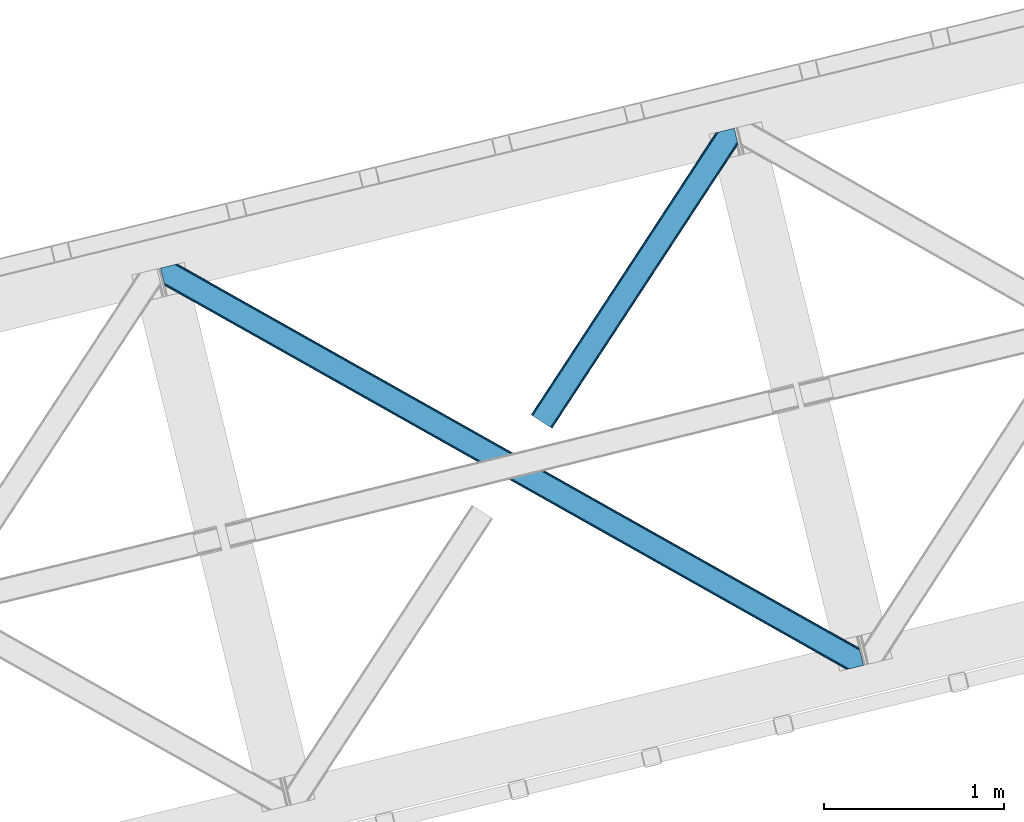
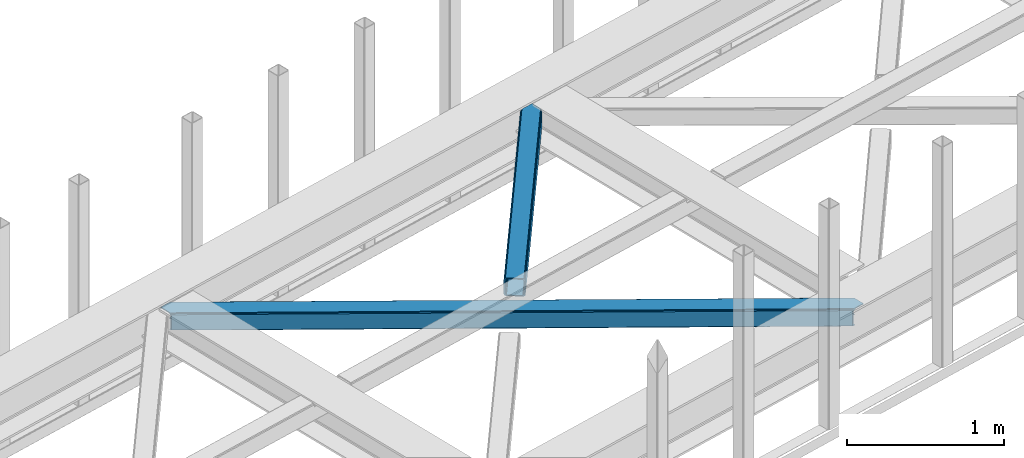
# One storey, part 35 of 67: 2 members.
"""IFC4 building model written with IfcOpenShell, lengths in millimetres."""

from ifc_helpers import new_model, entity, si_unit, converted_unit, derived_unit, direction, frame, origin, place, context, subcontext, project, spatial, triangles, type_object, element, save


model = new_model("IFC4")

# Units and contexts
model_context = context("Model", 3, precision=0.01, world=origin(), true_north=direction((6.12303176911189e-17, 1.0)))
plan_context = context("Plan", 3, precision=0.01, world=origin(), true_north=direction((6.12303176911189e-17, 1.0)))
body_context = subcontext(model_context, "Body", "Model", "MODEL_VIEW")
ifc_project = project(units=[si_unit("LENGTHUNIT", "METRE", prefix="MILLI"), si_unit("AREAUNIT", "SQUARE_METRE"), si_unit("VOLUMEUNIT", "CUBIC_METRE"), converted_unit("PLANEANGLEUNIT", "DEGREE", entity("IfcRatioMeasure", 0.0174532925199433), si_unit("PLANEANGLEUNIT", "RADIAN"), dimensions=[0, 0, 0, 0, 0, 0, 0]), si_unit("MASSUNIT", "GRAM", prefix="KILO"), derived_unit("MASSDENSITYUNIT", [(si_unit("MASSUNIT", "GRAM", prefix="KILO"), 1), (si_unit("LENGTHUNIT", "METRE"), -3)]), derived_unit("MOMENTOFINERTIAUNIT", [(si_unit("LENGTHUNIT", "METRE"), 4)]), si_unit("TIMEUNIT", "SECOND"), si_unit("FREQUENCYUNIT", "HERTZ"), si_unit("THERMODYNAMICTEMPERATUREUNIT", "DEGREE_CELSIUS"), derived_unit("THERMALTRANSMITTANCEUNIT", [(si_unit("MASSUNIT", "GRAM", prefix="KILO"), 1), (si_unit("THERMODYNAMICTEMPERATUREUNIT", "KELVIN"), -1), (si_unit("TIMEUNIT", "SECOND"), -3)]), derived_unit("VOLUMETRICFLOWRATEUNIT", [(si_unit("LENGTHUNIT", "METRE"), 3), (si_unit("TIMEUNIT", "SECOND"), -1)]), derived_unit("MASSFLOWRATEUNIT", [(si_unit("MASSUNIT", "GRAM", prefix="KILO"), 1), (si_unit("TIMEUNIT", "SECOND"), -1)]), derived_unit("ROTATIONALFREQUENCYUNIT", [(si_unit("TIMEUNIT", "SECOND"), -1)]), si_unit("ELECTRICCURRENTUNIT", "AMPERE"), si_unit("ELECTRICVOLTAGEUNIT", "VOLT"), si_unit("POWERUNIT", "WATT"), si_unit("FORCEUNIT", "NEWTON", prefix="KILO"), si_unit("ILLUMINANCEUNIT", "LUX"), si_unit("LUMINOUSFLUXUNIT", "LUMEN"), si_unit("LUMINOUSINTENSITYUNIT", "CANDELA"), derived_unit("USERDEFINED", [(si_unit("MASSUNIT", "GRAM", prefix="KILO"), -1), (si_unit("LENGTHUNIT", "METRE"), -2), (si_unit("TIMEUNIT", "SECOND"), 3), (si_unit("LUMINOUSFLUXUNIT", "LUMEN"), 1)]), derived_unit("LINEARVELOCITYUNIT", [(si_unit("LENGTHUNIT", "METRE"), 1), (si_unit("TIMEUNIT", "SECOND"), -1)]), si_unit("PRESSUREUNIT", "PASCAL"), derived_unit("USERDEFINED", [(si_unit("LENGTHUNIT", "METRE"), -2), (si_unit("MASSUNIT", "GRAM", prefix="KILO"), 1), (si_unit("TIMEUNIT", "SECOND"), -2)]), derived_unit("LINEARFORCEUNIT", [(si_unit("MASSUNIT", "GRAM", prefix="KILO"), 1), (si_unit("LENGTHUNIT", "METRE"), 1), (si_unit("TIMEUNIT", "SECOND"), -2), (si_unit("LENGTHUNIT", "METRE"), -1)]), derived_unit("PLANARFORCEUNIT", [(si_unit("MASSUNIT", "GRAM", prefix="KILO"), 1), (si_unit("LENGTHUNIT", "METRE"), 1), (si_unit("TIMEUNIT", "SECOND"), -2), (si_unit("LENGTHUNIT", "METRE"), -2)])], contexts=[model_context, plan_context])

# Site, building, storey
site_placement = place(None, origin())
site = spatial("IfcSite", under=ifc_project, at=site_placement, CompositionType="ELEMENT")
building_placement = place(site_placement, origin())
building = spatial("IfcBuilding", under=site, at=building_placement, CompositionType="ELEMENT")
storey_placement = place(building_placement, frame((0.0, 0.0, 19800.0)))
storey = spatial("IfcBuildingStorey", under=building, at=storey_placement, CompositionType="ELEMENT", Elevation=19800.0)

# Members
member_type_1 = type_object("IfcMemberType", PredefinedType="BRACE")
member_1_placement = place(storey_placement, frame((-36508.3901733398, 9647.04894561768, 3823.99987792968)))
element("IfcMember", 1, at=member_1_placement, inside=storey, type_object=member_type_1, ObjectType="Steel Horizontal Brace", PredefinedType="BRACE", context=body_context, shape_type="Tessellation", body=[
    triangles([(3809.34190063476, 0.0, 122.499499511719), (3811.23480834961, 0.461599731444949, 129.196765136719), (23.4590332031221, 2133.54825897217, 129.196765136719), (23.8915649414048, 2131.77511138916, 122.499499511719), (3816.62982788086, 1.77663574218786, 134.87548828125), (22.2288757324204, 2138.59446258545, 134.87548828125), (3824.70607910156, 3.74570159912037, 138.668280029298), (20.3871276855498, 2146.14632720947, 138.668280029298), (3834.23107910156, 6.06765289306531, 140.00075683594), (18.2151672363252, 2155.05508575439, 140.00075683594), (1916.9806640625, 1065.68088226318, 17.5012573242202), (2556.11839599609, 705.752851867675, 17.5012573242202), (3195.25147705078, 345.823658752441, 17.5012573242202), (3809.34190063476, 0.0, 17.5012573242202), (1277.84758300781, 1425.61007537842, 17.5012573242202), (638.712176513669, 1785.53926849365, 17.5012573242202), (23.8915649414048, 2131.77511138916, 17.5012573242202), (3885.46283569336, 97.7219421386708, 140.00075683594), (3903.67800292969, 22.9956893920898, 140.00075683594), (69.4469238281235, 2246.70995635986, 140.00075683594), (0.0, 2229.78191986084, 140.00075683594), (3883.29087524414, 106.63011932373, 138.668280029298), (78.971923828125, 2249.03190765381, 138.668280029298), (3881.44912719727, 114.183146667479, 134.87548828125), (87.0458496093779, 2251.00039215088, 134.87548828125), (3880.21896972656, 119.229350280761, 129.196765136719), (92.4408691406279, 2252.31542816162, 129.196765136719), (3879.78643798828, 121.001335144043, 122.499499511719), (94.3384277343721, 2252.77702789307, 122.499499511719), (3265.41928710938, 466.982542419433, 17.5012573242202), (3879.78643798828, 121.001335144043, 17.5012573242202), (2626.2955078125, 826.904759216308, 17.5012573242202), (1987.16940307617, 1186.82813873291, 17.5012573242202), (708.921844482422, 1906.67257232666, 17.5012573242202), (94.3384277343721, 2252.77702789307, 17.5012573242202), (1348.0456237793, 1546.75035552978, 17.5012573242202), (82.4856628417983, 2249.88766937256, 122.197192382813), (69.0143920898408, 2246.60531158447, 131.668707275392), (59.4893920898467, 2244.28336029053, 133.001184082033), (0.0, 2229.78191986084, 133.001184082033), (77.0906433105483, 2248.57263336182, 127.873590087893), (84.3808959960952, 2250.35043182373, 24.5008300781265), (77.0906433105483, 2248.57263336182, 12.1248413085959), (91.582781982419, 2252.10613861084, 9.49942016601563), (82.4856628417983, 2249.88766937256, 17.8035644531265), (84.3808959960952, 2250.35043182373, 115.499926757813), (72.3118652343765, 2247.40875091553, 9.49942016601563), (92.0548461914077, 2252.22124786377, 10.8691040039084), (1983.49055786133, 1180.86803741455, 24.5008300781265), (3882.05839233398, 111.689112854003, 115.499926757813), (2626.78850097656, 818.593638610839, 24.5008300781265), (3270.08876953125, 456.319239807128, 24.5008300781265), (3882.05839233398, 111.689112854003, 24.5008300781265), (1340.19028930664, 1543.14127349854, 24.5008300781265), (696.892346191409, 1905.41567230225, 24.5008300781265), (3882.48859863281, 109.917127990722, 122.197192382813), (3883.71875610352, 104.870924377441, 127.873590087893), (3885.56050415039, 97.318478393554, 131.668707275392), (3887.73246459961, 88.4097198486324, 133.001184082033), (3883.71875610352, 104.870924377441, 12.1248413085959), (3885.41865234375, 97.9004196166989, 8.52041015625218), (3880.59104003906, 117.702699279786, 8.52041015625218), (3903.67800292969, 22.9956893920898, 133.001184082033), (3882.48859863281, 109.917127990722, 17.8035644531265), (3880.37477416992, 118.591017150879, 10.9365417480476), (3844.18628540039, 8.49366760253906, 133.001184082033), (15.945538330081, 2164.36730804443, 133.001184082033), (3834.66128540039, 6.17229766845594, 131.668707275392), (18.1174987792983, 2155.45854949951, 131.668707275392), (3826.58735961914, 4.20381317138708, 127.873590087893), (19.959246826169, 2147.90668487549, 127.873590087893), (3821.19001464844, 2.88877716064417, 122.197192382813), (21.1894042968779, 2142.85931854248, 122.197192382813), (3819.29478149414, 2.42659606933557, 115.499926757813), (21.6219360351533, 2141.0873336792, 115.499926757813), (3208.50183105469, 346.395716857909, 24.5008300781265), (3819.29478149414, 2.42659606933557, 24.5008300781265), (2565.16435546875, 708.689881896973, 24.5008300781265), (1921.82920532227, 1070.98520965576, 24.5008300781265), (635.156579589842, 1795.57470245361, 24.5008300781265), (21.6219360351533, 2141.0873336792, 24.5008300781265), (1278.49405517578, 1433.28053741455, 24.5008300781265), (21.1894042968779, 2142.85931854248, 17.8035644531265), (23.263696289061, 2134.3505355835, 9.49942016601563), (19.959246826169, 2147.90668487549, 12.1248413085959), (23.3706665039063, 2133.90986480713, 10.8691040039084), (18.8686157226548, 2152.37617950439, 9.49942016601563), (3826.58735961914, 4.20381317138708, 12.1248413085959), (3812.8672668457, 0.859831237792605, 8.52041015625218), (3821.19001464844, 2.88877716064417, 17.8035644531265), (3834.04039306641, 6.02056274414099, 8.52041015625218), (3811.91848754883, 0.628450012207395, 10.9365417480476), (190.669757080075, 2055.62743377686, 9.49942016601563), (195.064837646481, 2037.60178985596, 9.49942016601563), (196.076403808591, 2037.6692276001, 8.49948120117188), (196.057800292969, 2037.42389373779, 8.8831787109375), (191.292974853517, 2056.67155609131, 8.85294799804615), (195.734564208986, 2037.48202972412, 9.08316650390771), (191.348785400391, 2055.8262588501, 9.20641479492406), (195.385748291017, 2037.54365386963, 9.29943237304906), (191.009271240233, 2055.72626495361, 9.35291748046802), (191.239489746091, 2057.51685333252, 8.49948120117188), (150.921020507813, 2218.69073638916, 9.49942016601563), (155.316101074219, 2200.66509246826, 9.49942016601563), (151.251232910159, 2218.34889678955, 9.25757446289208), (155.811419677731, 2200.23721160889, 9.42500610351635), (151.609350585939, 2217.98496551514, 8.99945068359375), (156.250927734378, 2199.30471038818, 9.11804809570458), (151.96281738281, 2217.619871521, 8.74132690429906), (156.692761230472, 2198.36407012939, 8.80643920898365), (152.295355224611, 2217.27919464111, 8.49948120117188), (157.132269287111, 2197.43156890869, 8.49948120117188), (3713.61751098633, 194.649165344237, 8.52041015625218), (3708.78989868164, 214.452607727051, 8.52041015625218), (3713.26636962891, 194.529405212403, 8.40181274414135), (3708.39922485351, 214.57120513916, 8.37390747070458), (3713.06405639648, 194.459642028809, 8.3320495605476), (3708.00622558594, 214.688639831542, 8.22740478515698), (3707.90623168946, 214.477024841308, 7.87393798828271), (3713.112890625, 193.949208068847, 8.19484863281468), (3707.80623779297, 214.266572570801, 7.52047119140843), (3713.24078979492, 192.705097961425, 7.85765991211156), (3713.36636352539, 191.464476013183, 7.52047119140843), (3264.76583862305, 465.822148132323, 10.8039916992202), (3262.90548706055, 462.516535949706, 5.12526855468968), (3260.11728515625, 457.569163513183, 1.33247680664135), (3708.58293457031, 211.087696838378, 5.59500732422021), (708.268395996092, 1905.51217803955, 10.8039916992202), (706.408044433592, 1902.20772857666, 5.12526855468968), (153.148791503903, 2213.77475738525, 5.12526855468968), (703.622167968751, 1897.26035614014, 1.33247680664135), (154.990539550781, 2206.22289276123, 1.33247680664135), (700.336322021481, 1891.42466583252, 0.0), (157.162499999999, 2197.31413421631, 0.0), (3710.29678344727, 204.050917053222, 1.33247680664135), (3712.46874389648, 195.142158508301, 0.0), (3256.83143920898, 451.734635925293, 0.0), (2625.64205932617, 825.744364929198, 10.8039916992202), (1986.51595458984, 1185.6677444458, 10.8039916992202), (1347.39450073242, 1545.58996124267, 10.8039916992202), (2623.77938232422, 822.438752746582, 5.12526855468968), (1984.65560302734, 1182.36213226318, 5.12526855468968), (1345.53182373047, 1542.28434906006, 5.12526855468968), (2620.99583129883, 817.492543029784, 1.33247680664135), (1981.8697265625, 1177.41475982666, 1.33247680664135), (1342.74594726563, 1537.33813934326, 1.33247680664135), (2617.70765991211, 811.656852722168, 0.0), (1978.58388061523, 1171.58023223877, 0.0), (1339.45777587891, 1531.50244903564, 0.0), (3746.51782836914, 55.4634750366204, 0.0), (3203.83932495117, 361.072727966308, 0.0), (2564.70391845703, 721.000758361815, 0.0), (1925.56851196289, 1080.92995147705, 0.0), (1286.43310546875, 1440.85798187256, 0.0), (647.297698974609, 1800.78717498779, 0.0), (191.209259033203, 2057.6342880249, 0.0), (3195.90492553711, 346.98405303955, 10.8039916992202), (639.365624999999, 1786.69966278076, 10.8039916992202), (641.225976562499, 1790.00527496338, 5.12526855468968), (195.222967529298, 2041.17366485596, 5.12526855468968), (3197.76760253906, 350.290827941893, 5.12526855468968), (3200.55115356445, 355.237037658691, 1.33247680664135), (3748.6874633789, 46.5547164916989, 1.33247680664135), (3752.58024902344, 34.8100845336903, 8.52041015625218), (3750.40363769531, 39.517936706543, 5.59500732422021), (3751.1780090332, 36.3402236938473, 7.52047119140843), (3752.24073486328, 35.1809921264648, 8.278564453125), (644.014178466794, 1794.9526473999, 1.33247680664135), (193.38121948242, 2048.72552947998, 1.33247680664135), (2561.41807250977, 715.166230773926, 1.33247680664135), (1922.28266601563, 1075.09426116943, 1.33247680664135), (1283.14725952149, 1435.02345428467, 1.33247680664135), (2558.63219604492, 710.218858337403, 5.12526855468968), (1919.49678955078, 1070.14805145264, 5.12526855468968), (1280.36370849609, 1430.07724456787, 5.12526855468968), (2556.76951904297, 706.913246154785, 10.8039916992202), (1917.63643798828, 1066.84243927002, 10.8039916992202), (1278.50103149414, 1426.77046966553, 10.8039916992202), (3745.62020874023, 59.1411575317379, 7.52047119140843), (3746.13878173828, 57.3430114746097, 7.90416870117406), (3746.67595825195, 56.436090087891, 8.10880737304615), (3747.30150146484, 55.3762710571282, 8.34832763671875), (3747.75263671875, 54.6129455566406, 8.52041015625218), (3211.01795654297, 350.861723327636, 12.1248413085959), (3217.08967895508, 361.643623352051, 6.99957275390625), (3213.80383300781, 355.80909576416, 8.3320495605476), (3744.24819946289, 64.7751159667969, 6.99957275390625), (643.744427490237, 1810.82377166748, 6.99957275390625), (188.939630126952, 2066.94651031494, 6.99957275390625), (637.672705078126, 1800.04187164307, 12.1248413085959), (640.456256103513, 1804.98808135986, 8.3320495605476), (635.810028076172, 1796.73625946045, 17.8035644531265), (3209.15760498047, 347.556111145019, 17.8035644531265), (2565.82012939453, 709.851438903808, 17.8035644531265), (1922.48265380859, 1072.14560394287, 17.8035644531265), (1279.14517822266, 1434.44093170166, 17.8035644531265), (2567.68048095703, 713.157051086426, 12.1248413085959), (1924.34300537109, 1075.45121612549, 12.1248413085959), (1281.00552978516, 1437.74654388428, 12.1248413085959), (2570.46635742187, 718.103260803222, 8.3320495605476), (1927.13120727539, 1080.39858856201, 8.3320495605476), (1283.79373168945, 1442.69275360107, 8.3320495605476), (2573.75220336914, 723.93895111084, 6.99957275390625), (1930.4147277832, 1086.2331161499, 6.99957275390625), (1287.07957763672, 1448.52844390869, 6.99957275390625), (694.376220703125, 1900.94966583252, 12.1248413085959), (691.58801879883, 1896.002293396, 8.3320495605476), (157.267144775389, 2196.88509063721, 8.41343994140698), (159.43212890625, 2188.00191192627, 6.99957275390625), (3261.50092163086, 441.070170593261, 6.99957275390625), (3264.78676757812, 446.905860900879, 8.3320495605476), (3714.73837280273, 185.831098937988, 6.99957275390625), (3267.57496948242, 451.853233337402, 12.1248413085959), (688.304498291014, 1890.16660308838, 6.99957275390625), (696.236572265625, 1904.25411529541, 17.8035644531265), (3269.43532104492, 455.157682800293, 17.8035644531265), (2621.48882446289, 809.18025970459, 8.3320495605476), (2618.20065307617, 803.344569396972, 6.99957275390625), (1978.1885559082, 1171.45349578857, 8.3320495605476), (1974.90270996094, 1165.61896820068, 6.99957275390625), (1331.60244140625, 1527.89220428467, 6.99957275390625), (1334.89061279297, 1533.72789459228, 8.3320495605476), (2624.27237548828, 814.126469421386, 12.1248413085959), (1980.97443237305, 1176.4008682251, 12.1248413085959), (1337.67416381836, 1538.67526702881, 12.1248413085959), (2626.13737792968, 817.432081604004, 17.8035644531265), (1982.83478393555, 1179.70648040771, 17.8035644531265), (1339.53684082031, 1541.98087921143, 17.8035644531265)], [[1, 2, 3], [3, 4, 1], [2, 5, 6], [6, 3, 2], [5, 7, 8], [8, 6, 5], [7, 9, 10], [10, 8, 7], [11, 1, 4], [1, 12, 13], [11, 12, 1], [13, 14, 1], [15, 4, 16], [4, 15, 11], [17, 16, 4], [9, 18, 10], [9, 19, 18], [20, 10, 18], [21, 10, 20], [18, 22, 23], [23, 20, 18], [22, 24, 25], [25, 23, 22], [24, 26, 27], [27, 25, 24], [26, 28, 29], [29, 27, 26], [30, 28, 31], [28, 30, 32], [28, 33, 29], [33, 28, 32], [34, 35, 29], [36, 29, 33], [29, 36, 34], [37, 29, 27], [38, 23, 20], [21, 39, 20], [39, 21, 40], [39, 38, 20], [41, 23, 38], [41, 37, 25], [25, 23, 41], [27, 25, 37], [42, 35, 29], [43, 44, 45], [37, 46, 29], [43, 47, 44], [42, 45, 35], [46, 42, 29], [48, 35, 45], [45, 44, 48], [49, 50, 46], [50, 51, 52], [49, 51, 50], [52, 53, 50], [54, 46, 55], [46, 54, 49], [42, 55, 46], [50, 56, 46], [37, 46, 56], [56, 57, 37], [41, 37, 57], [57, 58, 41], [38, 41, 58], [58, 59, 38], [39, 38, 59], [57, 24, 22], [60, 61, 62], [24, 57, 56], [58, 57, 22], [58, 18, 59], [19, 59, 18], [59, 19, 63], [58, 22, 18], [31, 28, 53], [62, 64, 60], [64, 31, 53], [65, 64, 62], [65, 31, 64], [28, 50, 53], [56, 26, 24], [28, 26, 56], [50, 28, 56], [59, 66, 67], [66, 59, 63], [67, 39, 59], [40, 39, 67], [66, 68, 67], [69, 67, 68], [68, 70, 69], [71, 69, 70], [70, 72, 71], [73, 71, 72], [72, 74, 73], [75, 73, 74], [76, 74, 77], [74, 76, 78], [74, 79, 75], [79, 74, 78], [80, 81, 75], [82, 75, 79], [75, 82, 80], [83, 84, 85], [81, 4, 17], [17, 86, 83], [86, 84, 83], [83, 81, 17], [75, 4, 81], [73, 71, 6], [3, 73, 6], [3, 4, 73], [75, 73, 4], [71, 8, 6], [69, 8, 71], [87, 85, 84], [69, 67, 10], [69, 10, 8], [67, 21, 10], [67, 40, 21], [72, 1, 2], [68, 7, 9], [19, 66, 9], [66, 19, 63], [66, 68, 9], [70, 7, 68], [70, 72, 5], [5, 7, 70], [2, 5, 72], [77, 14, 1], [88, 89, 90], [72, 74, 1], [88, 91, 89], [77, 90, 14], [74, 77, 1], [92, 14, 90], [90, 89, 92], [93, 94, 84], [84, 87, 93], [95, 96, 97], [96, 98, 99], [99, 98, 100], [101, 100, 94], [94, 93, 101], [100, 101, 99], [99, 97, 96], [97, 102, 95], [103, 104, 44], [47, 44, 104], [105, 106, 104], [107, 108, 106], [109, 110, 108], [111, 112, 110], [110, 109, 111], [108, 107, 109], [106, 105, 107], [104, 103, 105], [62, 61, 113], [113, 114, 62], [115, 116, 114], [117, 118, 116], [116, 115, 117], [119, 118, 120], [121, 119, 122], [122, 123, 121], [120, 122, 119], [117, 120, 118], [114, 113, 115], [124, 30, 31], [125, 124, 118], [118, 119, 125], [119, 121, 125], [124, 65, 114], [114, 116, 124], [116, 118, 124], [65, 62, 114], [126, 125, 127], [48, 128, 103], [128, 129, 130], [130, 111, 128], [128, 109, 107], [109, 128, 111], [128, 105, 103], [105, 128, 107], [128, 48, 35], [35, 34, 128], [103, 44, 48], [129, 131, 132], [132, 130, 129], [131, 133, 134], [134, 132, 131], [135, 136, 137], [137, 126, 135], [127, 135, 126], [121, 127, 125], [31, 65, 124], [30, 124, 138], [138, 32, 30], [32, 138, 33], [139, 33, 138], [33, 139, 36], [140, 36, 139], [36, 140, 34], [128, 34, 140], [124, 125, 138], [141, 138, 125], [138, 141, 142], [142, 139, 138], [139, 142, 143], [143, 140, 139], [140, 143, 129], [129, 128, 140], [125, 126, 144], [144, 141, 125], [141, 144, 145], [145, 142, 141], [142, 145, 146], [146, 143, 142], [143, 146, 129], [131, 129, 146], [126, 137, 144], [147, 144, 137], [144, 147, 145], [148, 145, 147], [145, 148, 146], [149, 146, 148], [146, 149, 131], [133, 131, 149], [136, 150, 151], [137, 151, 147], [151, 137, 136], [148, 152, 153], [152, 147, 151], [148, 147, 152], [133, 149, 154], [153, 149, 148], [149, 153, 154], [155, 133, 154], [156, 133, 155], [134, 133, 156], [157, 92, 14], [158, 16, 17], [159, 96, 95], [158, 86, 94], [94, 159, 158], [94, 98, 159], [86, 84, 94], [95, 160, 159], [161, 162, 163], [92, 157, 164], [157, 161, 165], [165, 166, 157], [167, 164, 157], [157, 166, 167], [164, 89, 92], [163, 165, 161], [150, 163, 162], [162, 151, 150], [155, 168, 169], [169, 156, 155], [168, 159, 160], [160, 169, 168], [17, 86, 158], [14, 13, 157], [151, 162, 152], [170, 152, 162], [152, 170, 153], [171, 153, 170], [153, 171, 172], [172, 154, 153], [154, 172, 168], [168, 155, 154], [162, 161, 170], [173, 170, 161], [170, 173, 174], [174, 171, 170], [171, 174, 175], [175, 172, 171], [172, 175, 168], [159, 168, 175], [161, 157, 176], [176, 173, 161], [173, 176, 174], [177, 174, 176], [174, 177, 175], [178, 175, 177], [175, 178, 159], [158, 159, 178], [157, 13, 12], [12, 176, 157], [176, 12, 11], [11, 177, 176], [177, 11, 15], [15, 178, 177], [178, 15, 16], [16, 158, 178], [166, 179, 180], [166, 180, 181], [167, 181, 182], [167, 182, 183], [91, 89, 183], [164, 183, 89], [184, 183, 182], [88, 91, 183], [183, 184, 88], [185, 180, 179], [182, 185, 186], [182, 181, 185], [180, 185, 181], [179, 187, 185], [188, 189, 102], [93, 85, 190], [93, 87, 85], [102, 190, 191], [190, 102, 97], [97, 99, 190], [80, 192, 81], [83, 81, 192], [192, 190, 83], [85, 83, 190], [102, 191, 188], [182, 186, 184], [90, 88, 184], [184, 193, 90], [77, 90, 193], [193, 76, 77], [76, 193, 78], [194, 78, 193], [78, 194, 79], [195, 79, 194], [79, 195, 82], [196, 82, 195], [82, 196, 80], [192, 80, 196], [193, 184, 197], [197, 194, 193], [194, 197, 195], [198, 195, 197], [195, 198, 199], [199, 196, 195], [196, 199, 190], [190, 192, 196], [184, 186, 197], [200, 197, 186], [197, 200, 201], [201, 198, 197], [198, 201, 202], [202, 199, 198], [199, 202, 191], [191, 190, 199], [186, 185, 203], [203, 200, 186], [200, 203, 201], [204, 201, 203], [201, 204, 202], [205, 202, 204], [202, 205, 191], [188, 191, 205], [206, 106, 108], [108, 207, 206], [108, 110, 207], [110, 208, 207], [104, 206, 43], [43, 47, 104], [207, 208, 209], [210, 123, 122], [122, 211, 210], [122, 117, 211], [210, 212, 123], [213, 211, 117], [61, 60, 113], [213, 113, 60], [209, 214, 207], [206, 215, 45], [45, 43, 206], [215, 55, 42], [42, 45, 215], [64, 53, 216], [52, 216, 53], [60, 64, 213], [216, 213, 64], [210, 211, 217], [217, 218, 210], [218, 217, 219], [219, 220, 218], [220, 219, 221], [222, 221, 219], [221, 222, 207], [207, 214, 221], [211, 213, 217], [223, 217, 213], [217, 223, 219], [224, 219, 223], [219, 224, 222], [225, 222, 224], [222, 225, 206], [206, 207, 222], [213, 216, 226], [226, 223, 213], [223, 226, 227], [227, 224, 223], [224, 227, 228], [228, 225, 224], [225, 228, 206], [215, 206, 228], [216, 52, 51], [51, 226, 216], [226, 51, 227], [49, 227, 51], [227, 49, 228], [54, 228, 49], [228, 54, 215], [55, 215, 54], [209, 134, 189], [132, 208, 130], [208, 132, 134], [130, 208, 111], [134, 209, 208], [189, 134, 156], [169, 102, 156], [102, 169, 160], [156, 102, 189], [160, 95, 102], [136, 212, 187], [123, 127, 121], [136, 123, 212], [123, 135, 127], [123, 136, 135], [150, 136, 187], [179, 150, 187], [165, 179, 166], [179, 163, 150], [179, 165, 163], [203, 185, 210], [210, 218, 203], [218, 204, 203], [204, 218, 220], [185, 212, 210], [185, 187, 212], [214, 188, 221], [188, 214, 189], [209, 189, 214], [205, 221, 188], [220, 205, 204], [221, 205, 220]]),
])
member_type_2 = type_object("IfcMemberType", PredefinedType="BRACE")
member_2_placement = place(storey_placement, frame((-34450.7785583496, 10986.0770965576, 3823.99987792968)))
element("IfcMember", 2, at=member_2_placement, inside=storey, type_object=member_type_2, ObjectType="Steel Horizontal Brace", PredefinedType="BRACE", context=body_context, shape_type="Tessellation", body=[
    triangles([(994.774163818358, 1564.02778930664, 0.0), (1028.82324829101, 1424.34794311523, 0.0), (14.6409667968692, 67.1040435791019, 0.0), (102.486767578121, 9.58662414550781, 0.0), (1.11388549804542, 75.9604797363281, 10.8039916992202), (0.0, 76.6906677246097, 17.5012573242202), (1025.02813110351, 1642.17999572754, 17.5012573242202), (4.28811035156104, 73.8826995849613, 5.12526855468968), (990.476751708979, 1585.8776184082, 9.49942016601563), (990.04654541015, 1584.44747314453, 8.74132690429906), (989.907019042963, 1583.99284973144, 8.49948120117188), (990.762780761717, 1580.48841247559, 5.12526855468968), (1027.30938720703, 1642.73577575684, 10.8691040039084), (1027.78145141601, 1642.85088500977, 9.49942016601563), (992.602203369141, 1572.93654785156, 1.33247680664135), (9.03898315429251, 70.7724243164066, 1.33247680664135), (1025.02813110351, 1642.17999572754, 122.499499511719), (0.0, 76.6906677246097, 122.499499511719), (1026.92103881836, 1642.64159545898, 129.196765136719), (1.11388549804542, 75.9604797363281, 129.196765136719), (1032.31605834961, 1643.95663146973, 134.87548828125), (4.28811035156104, 73.8826995849613, 134.87548828125), (1040.39463500976, 1645.9251159668, 138.668280029298), (9.03898315429251, 70.7724243164066, 138.668280029298), (1049.91963500976, 1648.24706726074, 140.00075683594), (14.6409667968692, 67.1040435791019, 140.00075683594), (994.871832275385, 1567.8519744873, 9.49942016601563), (994.762536621092, 1567.00783996582, 9.2947814941399), (994.648590087891, 1566.15091552734, 9.08781738281323), (994.541619873045, 1565.30678100586, 8.8831787109375), (994.746258544918, 1564.14522399902, 8.49948120117188), (1047.05469360351, 1647.54827270508, 9.49942016601563), (14.8944396972656, 66.9377746582031, 8.3320495605476), (20.4987487792969, 63.2705566406257, 6.99957275390625), (997.043792724609, 1554.7155670166, 6.99957275390625), (10.1458923339815, 70.0480499267578, 12.1248413085959), (1042.27359008789, 1646.38322753906, 12.1248413085959), (1036.87857055664, 1645.06819152832, 17.8035644531265), (1034.98333740234, 1644.60659179688, 24.5008300781265), (6.96934204101126, 72.1258300781246, 17.8035644531265), (5.85545654296584, 72.8560180664063, 24.5008300781265), (1026.55361938477, 1433.66016540527, 6.99957275390625), (96.6289855957002, 13.4212738037113, 6.99957275390625), (1028.71860351562, 1424.77698669434, 8.41343994140698), (1032.83463134765, 1407.88615722656, 5.12526855468968), (1033.6903930664, 1404.38288269043, 8.49948120117188), (1030.99520874023, 1415.43918457031, 1.33247680664135), (1034.98333740234, 1644.60659179688, 115.499926757813), (5.85545654296584, 72.8560180664063, 115.499926757813), (1050.34751586914, 1648.35171203613, 131.668707275392), (1059.87251586914, 1650.67366333008, 133.001184082033), (20.4987487792969, 63.2705566406257, 133.001184082033), (14.8944396972656, 66.9377746582031, 131.668707275392), (1042.27359008789, 1646.38322753906, 127.873590087893), (10.1458923339815, 70.0480499267578, 127.873590087893), (1036.87857055664, 1645.06819152832, 122.197192382813), (6.96934204101126, 72.1258300781246, 122.197192382813), (1128.10788574218, 1667.30636901856, 140.00075683594), (1128.10788574218, 1667.30636901856, 133.001184082033), (1144.33015136718, 1600.75810546875, 140.00075683594), (102.486767578121, 9.58662414550781, 140.00075683594), (1142.06052246093, 1610.07032775879, 133.001184082033), (96.6289855957002, 13.4212738037113, 133.001184082033), (1146.5021118164, 1591.84934692383, 138.668280029298), (108.088751220697, 5.91824340820313, 138.668280029298), (1148.34385986328, 1584.2974822998, 134.87548828125), (112.839624023436, 2.80796813964844, 134.87548828125), (1149.57401733398, 1579.2501159668, 129.196765136719), (116.011523437497, 0.730187988281614, 129.196765136719), (1150.00422363281, 1577.47813110351, 122.499499511719), (117.125408935543, 0.0, 122.499499511719), (1150.00422363281, 1577.47813110351, 17.5012573242202), (117.125408935543, 0.0, 17.5012573242202), (106.981842041016, 6.64261779785193, 127.873590087893), (110.156066894531, 4.5648376464851, 122.197192382813), (111.269952392577, 3.83464965820349, 115.499926757813), (102.233294677731, 9.75289306640661, 131.668707275392), (116.011523437497, 0.730187988281614, 10.8039916992202), (106.981842041016, 6.64261779785193, 12.1248413085959), (112.839624023436, 2.80796813964844, 5.12526855468968), (111.269952392577, 3.83464965820349, 24.5008300781265), (110.156066894531, 4.5648376464851, 17.8035644531265), (108.088751220697, 5.91824340820313, 1.33247680664135), (102.233294677731, 9.75289306640661, 8.3320495605476), (1147.30206298828, 1588.56233825684, 122.197192382813), (1147.73459472656, 1586.79035339356, 115.499926757813), (1146.07190551757, 1593.60854187012, 127.873590087893), (1144.23248291016, 1601.16156921387, 131.668707275392), (1147.73459472656, 1586.79035339356, 24.5008300781265), (1147.21369628906, 1588.92510681152, 17.8686767578147), (1149.994921875, 1577.51650085449, 16.5013183593765), (1147.10672607421, 1589.36577758789, 16.5013183593765), (1145.27660522461, 1573.10863037109, 10.8714294433594), (1034.62056884765, 1404.788671875, 9.49942016601563), (1144.12783813477, 1572.03544006348, 9.49942016601563), (1142.79303588867, 1588.59838256836, 12.1248413085959), (1030.22548828125, 1422.8143157959, 9.49942016601563), (1029.19764404296, 1423.6724029541, 8.80643920898365), (1139.73275756836, 1590.06108398438, 9.49942016601563)], [[1, 2, 3], [4, 3, 2], [5, 6, 7], [8, 9, 10], [11, 12, 8], [5, 13, 9], [9, 8, 5], [13, 14, 9], [15, 1, 16], [3, 16, 1], [12, 15, 8], [16, 8, 15], [7, 13, 5], [17, 7, 6], [6, 18, 17], [19, 17, 20], [18, 20, 17], [21, 19, 22], [20, 22, 19], [23, 21, 24], [22, 24, 21], [25, 23, 26], [24, 26, 23], [27, 28, 9], [28, 29, 10], [29, 30, 10], [30, 31, 11], [14, 32, 27], [27, 9, 14], [33, 34, 35], [36, 33, 31], [31, 30, 36], [28, 36, 29], [28, 27, 36], [36, 30, 29], [32, 37, 27], [36, 27, 37], [35, 31, 33], [38, 39, 40], [41, 40, 39], [37, 38, 36], [40, 36, 38], [42, 35, 34], [34, 43, 42], [1, 35, 42], [31, 12, 11], [1, 31, 35], [31, 15, 12], [31, 1, 15], [2, 1, 42], [44, 2, 42], [45, 44, 46], [44, 47, 2], [44, 45, 47], [39, 48, 49], [49, 41, 39], [50, 51, 52], [52, 53, 50], [54, 50, 53], [53, 55, 54], [56, 54, 55], [55, 57, 56], [48, 56, 57], [57, 49, 48], [56, 17, 19], [50, 23, 25], [58, 51, 25], [51, 58, 59], [51, 50, 25], [54, 23, 50], [54, 56, 21], [21, 23, 54], [19, 21, 56], [39, 7, 17], [37, 14, 38], [56, 48, 17], [37, 32, 14], [39, 38, 7], [48, 39, 17], [13, 7, 38], [38, 14, 13], [60, 25, 61], [25, 60, 58], [26, 61, 25], [51, 62, 63], [51, 59, 62], [63, 52, 51], [64, 60, 61], [61, 65, 64], [66, 64, 65], [65, 67, 66], [68, 66, 67], [67, 69, 68], [70, 68, 69], [69, 71, 70], [72, 70, 71], [71, 73, 72], [69, 74, 75], [76, 73, 71], [69, 75, 71], [69, 67, 74], [75, 76, 71], [74, 67, 65], [63, 61, 26], [61, 77, 65], [77, 61, 63], [77, 74, 65], [78, 79, 80], [81, 73, 76], [73, 82, 78], [82, 73, 81], [78, 82, 79], [4, 43, 3], [83, 80, 79], [79, 84, 83], [84, 43, 4], [4, 83, 84], [55, 24, 22], [26, 52, 63], [26, 53, 52], [53, 26, 24], [55, 53, 24], [49, 18, 6], [20, 57, 55], [22, 20, 55], [57, 20, 18], [49, 57, 18], [16, 36, 8], [3, 43, 34], [34, 33, 3], [33, 36, 16], [16, 3, 33], [5, 8, 36], [6, 41, 49], [40, 6, 5], [6, 40, 41], [40, 5, 36], [85, 86, 75], [76, 75, 86], [87, 85, 74], [75, 74, 85], [88, 87, 77], [74, 77, 87], [62, 88, 63], [77, 63, 88], [86, 89, 76], [81, 76, 89], [90, 91, 92], [70, 72, 89], [72, 90, 89], [89, 86, 70], [72, 91, 90], [85, 70, 86], [68, 70, 85], [66, 85, 87], [85, 66, 68], [87, 64, 66], [88, 64, 87], [88, 62, 60], [88, 60, 64], [62, 58, 60], [62, 59, 58], [73, 78, 93], [93, 72, 73], [94, 93, 78], [94, 95, 93], [80, 45, 46], [46, 78, 80], [46, 94, 78], [47, 45, 83], [80, 83, 45], [2, 47, 4], [83, 4, 47], [93, 91, 72], [82, 81, 89], [82, 92, 96], [82, 90, 92], [84, 97, 98], [79, 96, 97], [97, 84, 79], [96, 99, 97], [43, 84, 44], [44, 42, 43], [96, 79, 82], [89, 90, 82], [96, 91, 93], [96, 92, 91], [96, 95, 99], [93, 95, 96], [99, 95, 97], [94, 97, 95]]),
])

save(model, "model.ifc")
